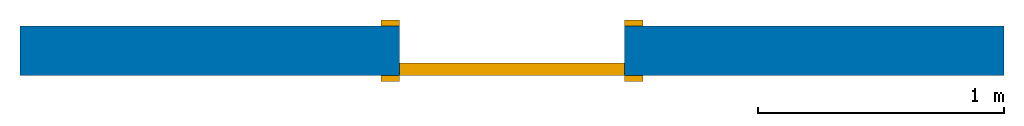
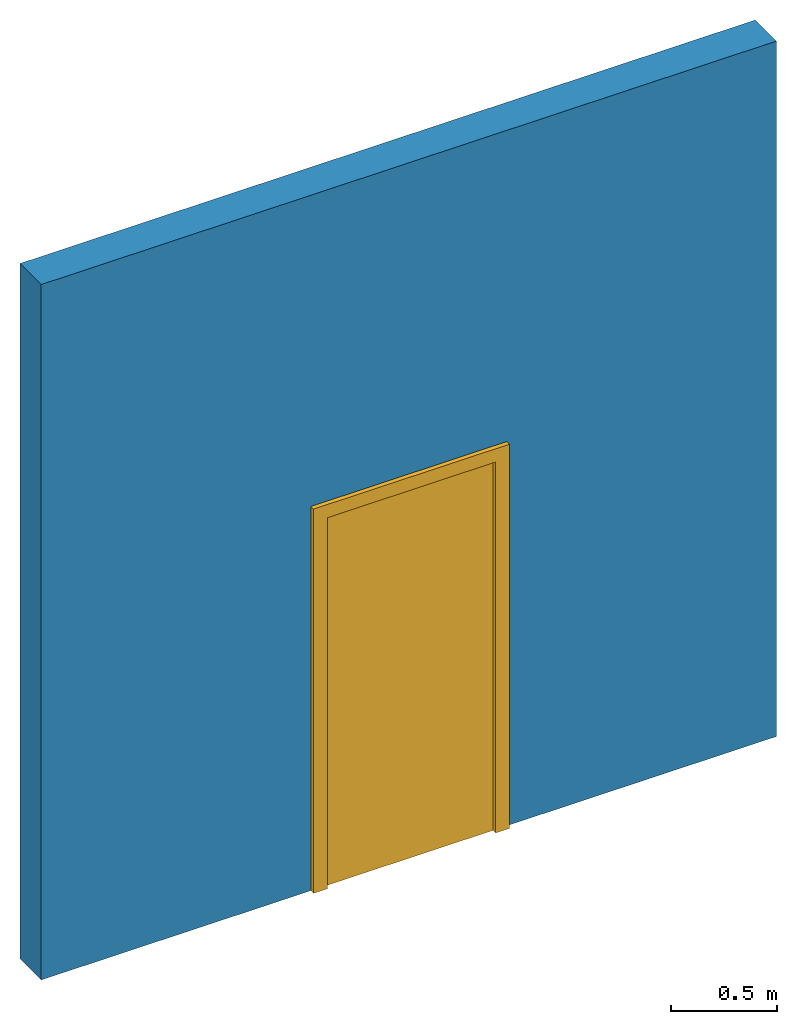
# One storey: 1 door, 1 wall, 1 opening.
"""IFC2X3 building model written with IfcOpenShell, lengths in millimetres."""

from ifc_helpers import new_model, entity, si_unit, converted_unit, derived_unit, direction, frame, frame_2d, origin, place, context, subcontext, project, spatial, polyline, rectangle, outline, extrude, source, transform, mapped, material, material_list, layer, layer_set, layer_usage, type_object, type_shapes, element, fill, save


model = new_model("IFC2X3")

# Units and contexts
model_context = context("Model", 3, precision=0.01, world=origin(), true_north=direction((6.12303176911189e-17, 1.0)))
body_context = subcontext(model_context, "Body", "Model", "MODEL_VIEW")
ifc_project = project(units=[si_unit("LENGTHUNIT", "METRE", prefix="MILLI"), si_unit("AREAUNIT", "SQUARE_METRE"), si_unit("VOLUMEUNIT", "CUBIC_METRE"), converted_unit("PLANEANGLEUNIT", "DEGREE", entity("IfcRatioMeasure", 0.0174532925199433), si_unit("PLANEANGLEUNIT", "RADIAN"), dimensions=[0, 0, 0, 0, 0, 0, 0]), si_unit("MASSUNIT", "GRAM", prefix="KILO"), derived_unit("MASSDENSITYUNIT", [(si_unit("MASSUNIT", "GRAM", prefix="KILO"), 1), (si_unit("LENGTHUNIT", "METRE"), -3)]), derived_unit("MOMENTOFINERTIAUNIT", [(si_unit("LENGTHUNIT", "METRE"), 4)]), si_unit("TIMEUNIT", "SECOND"), si_unit("FREQUENCYUNIT", "HERTZ"), si_unit("THERMODYNAMICTEMPERATUREUNIT", "DEGREE_CELSIUS"), derived_unit("THERMALTRANSMITTANCEUNIT", [(si_unit("MASSUNIT", "GRAM", prefix="KILO"), 1), (si_unit("THERMODYNAMICTEMPERATUREUNIT", "KELVIN"), -1), (si_unit("TIMEUNIT", "SECOND"), -3)]), derived_unit("VOLUMETRICFLOWRATEUNIT", [(si_unit("LENGTHUNIT", "METRE"), 3), (si_unit("TIMEUNIT", "SECOND"), -1)]), si_unit("ELECTRICCURRENTUNIT", "AMPERE"), si_unit("ELECTRICVOLTAGEUNIT", "VOLT"), si_unit("POWERUNIT", "WATT"), si_unit("FORCEUNIT", "NEWTON", prefix="KILO"), si_unit("ILLUMINANCEUNIT", "LUX"), si_unit("LUMINOUSFLUXUNIT", "LUMEN"), si_unit("LUMINOUSINTENSITYUNIT", "CANDELA"), derived_unit("USERDEFINED", [(si_unit("MASSUNIT", "GRAM", prefix="KILO"), -1), (si_unit("LENGTHUNIT", "METRE"), -2), (si_unit("TIMEUNIT", "SECOND"), 3), (si_unit("LUMINOUSFLUXUNIT", "LUMEN"), 1)]), derived_unit("LINEARVELOCITYUNIT", [(si_unit("LENGTHUNIT", "METRE"), 1), (si_unit("TIMEUNIT", "SECOND"), -1)]), si_unit("PRESSUREUNIT", "PASCAL"), derived_unit("USERDEFINED", [(si_unit("LENGTHUNIT", "METRE"), -2), (si_unit("MASSUNIT", "GRAM", prefix="KILO"), 1), (si_unit("TIMEUNIT", "SECOND"), -2)]), derived_unit("LINEARFORCEUNIT", [(si_unit("MASSUNIT", "GRAM", prefix="KILO"), 1), (si_unit("LENGTHUNIT", "METRE"), 1), (si_unit("TIMEUNIT", "SECOND"), -2), (si_unit("LENGTHUNIT", "METRE"), -1)]), derived_unit("PLANARFORCEUNIT", [(si_unit("MASSUNIT", "GRAM", prefix="KILO"), 1), (si_unit("LENGTHUNIT", "METRE"), 1), (si_unit("TIMEUNIT", "SECOND"), -2), (si_unit("LENGTHUNIT", "METRE"), -2)])], contexts=[model_context])

# Site, building, storey
site_placement = place(None, origin())
site = spatial("IfcSite", under=ifc_project, at=site_placement, CompositionType="ELEMENT")
building_placement = place(site_placement, origin())
building = spatial("IfcBuilding", under=site, at=building_placement, Name="// BUILDING/NAME //", CompositionType="ELEMENT")
storey_placement = place(building_placement, origin())
storey = spatial("IfcBuildingStorey", under=building, at=storey_placement, Name="Level 1", CompositionType="ELEMENT", Elevation=0.0)

# Wall, opening, door
ifc_material_1 = material(Name="Default Wall")
ifc_layer = layer(ifc_material_1, 200.0)
ifc_layer_set = layer_set([ifc_layer], Name="Basic Wall:Bearing Wall")
ifc_layer_usage = layer_usage(ifc_layer_set, "AXIS2", "NEGATIVE", 100.0)
wall_type = type_object("IfcWallType", Name="Basic Wall:Bearing Wall", PredefinedType="STANDARD", material=ifc_layer_set)
wall_placement = place(storey_placement, frame((-1693.30861181816, -5.56914852525364, 0.0)))
wall = element("IfcWallStandardCase", 1, at=wall_placement, inside=storey, type_object=wall_type, material=ifc_layer_usage, Name="Basic Wall:Bearing Wall", ObjectType="Basic Wall:Bearing Wall", context=body_context, shape_type="SweptSolid", body=[
    extrude(rectangle(XDim=4000.0, YDim=200.0, at=frame_2d((2000.0, 0.0), x_axis=(-1.0, 0.0))), origin(), (0.0, 0.0, 1.0), 4000.0),
])
opening_placement = place(wall_placement, frame((2457.5, 100.0, 0.0)))
opening = element("IfcOpeningElement", 2, at=opening_placement, cuts=wall, Name="M_Single-Flush:Outside door:1", ObjectType="Opening", context=body_context, shape_type="SweptSolid", body=[
    extrude(rectangle(XDim=915.0, YDim=2134.0, at=frame_2d((1067.0, 457.5), x_axis=(0.0, 1.0))), frame((0.0, 0.0, 0.0), z_axis=(0.0, -1.0, 0.0), x_axis=(0.0, 0.0, 1.0)), (0.0, 0.0, 1.0), 200.0),
])
ifc_material_2 = material(Name="Door - Frame")
ifc_material_3 = material(Name="Door - Panel")
ifc_material_list_1 = material_list([ifc_material_2, ifc_material_3])
ifc_material_list_2 = material_list([ifc_material_2, ifc_material_3])
door_style = type_object("IfcDoorStyle", Name="M_Single-Flush:Outside door", ConstructionType="NOTDEFINED", OperationType="SINGLE_SWING_RIGHT", ParameterTakesPrecedence=False, Sizeable=False, material=ifc_material_list_2)
shared_shape = source(origin(), body_context, "Body", "SweptSolid", [
    extrude(outline(polyline([(-533.5, -1124.0), (533.5, -1124.0), (533.5, 1086.0), (457.5, 1086.0), (457.5, -1048.0), (-457.5, -1048.0), (-457.5, 1086.0), (-533.5, 1086.0), (-533.5, -1124.0)])), frame((457.500000000001, 200.0, 1086.0), z_axis=(0.0, 1.0, 0.0), x_axis=(1.0, 0.0, 0.0)), (0.0, 0.0, 1.0), 24.9999999999945),
    extrude(outline(polyline([(-1124.0, -533.499999999997), (1086.0, -533.499999999997), (1086.0, -457.500000000007), (-1048.0, -457.500000000007), (-1048.0, 457.500000000002), (1086.0, 457.500000000002), (1086.0, 533.500000000003), (-1124.0, 533.500000000003), (-1124.0, -533.499999999997)])), frame((457.500000000003, -25.0, 1086.0), z_axis=(0.0, 1.0, 0.0), x_axis=(0.0, 0.0, -1.0)), (0.0, 0.0, 1.0), 25.0000000000056),
    extrude(rectangle(XDim=51.0, YDim=915.0, at=frame_2d((-5.32907051820075e-15, 0.0), x_axis=(1.0, 0.0))), frame((457.5, 174.500000000001, 0.0), z_axis=(0.0, 0.0, 1.0), x_axis=(0.0, 1.0, 0.0)), (0.0, 0.0, 1.0), 2134.0),
])
type_shapes(door_style, [shared_shape])
door_placement = place(opening_placement, frame((0.0, 0.0, 0.0), z_axis=(0.0, 0.0, 1.0), x_axis=(-1.0, 0.0, 0.0)))
door = element("IfcDoor", 3, at=door_placement, inside=storey, type_object=door_style, material=ifc_material_list_1, Name="M_Single-Flush:Outside door", ObjectType="M_Single-Flush:Outside door", OverallHeight=2134.0, OverallWidth=915.0, context=body_context, shape_type="MappedRepresentation", body=[
    mapped(shared_shape, transform((0.0, 0.0, 0.0), scale=1.0)),
])
fill(opening, door)

save(model, "model.ifc")
